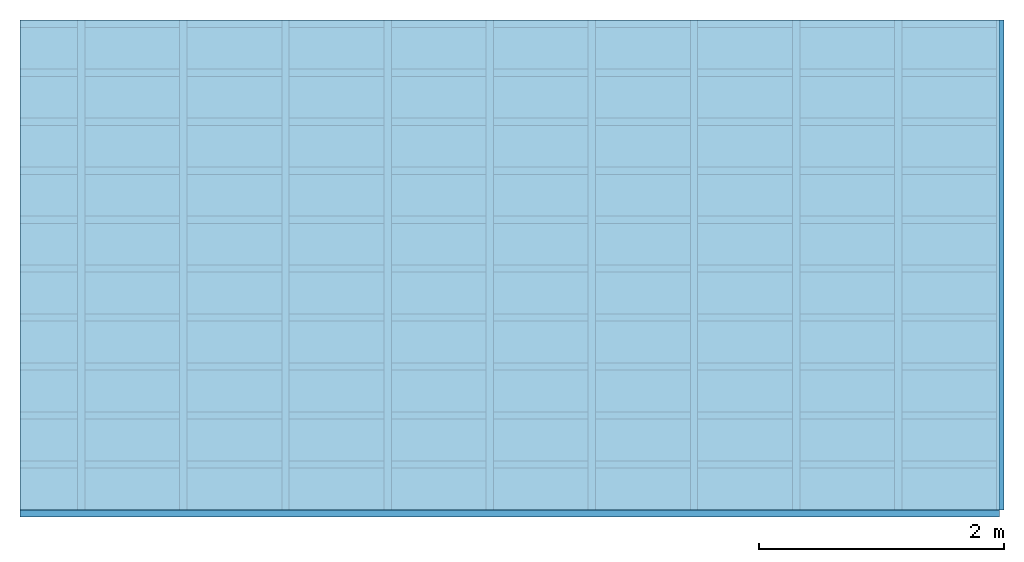
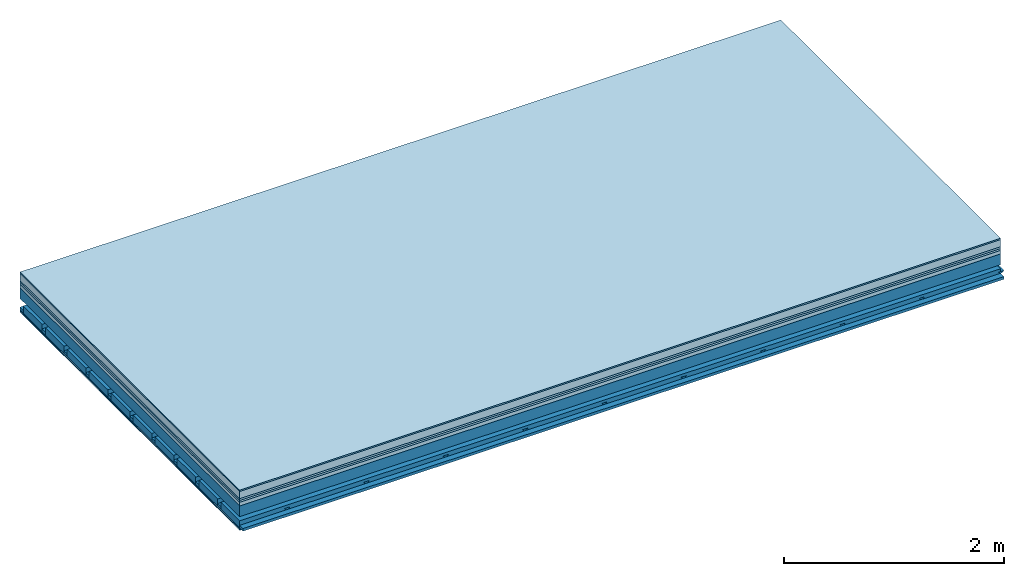
# One storey: 8 plates, 4 members, 1 element without a shape of its own.
"""IFC4 building model written with IfcOpenShell, lengths in metres."""

from ifc_helpers import new_model, si_unit, derived_unit, direction, frame, frame_2d, origin, origin_with_axes, place, context, project, spatial, polyline, rectangle, outline, extrude, material, layer, layer_set, type_object, element, aggregate, save


model = new_model("IFC4")

# Units and contexts
plan_context = context("Plan", 3, precision=1e-05, world=origin(), true_north=direction((0.0, 1.0)))
model_context = context("Model", 3, precision=1e-05, world=origin(), true_north=direction((0.0, 1.0)))
ifc_project = project(units=[si_unit("LENGTHUNIT", "METRE"), derived_unit("SOUNDPRESSUREUNIT", [(si_unit("PRESSUREUNIT", "PASCAL", prefix="MICRO"), 0)]), si_unit("ENERGYUNIT", "JOULE", prefix="MEGA"), si_unit("MASSUNIT", "GRAM", prefix="KILO"), derived_unit("THERMALTRANSMITTANCEUNIT", [(si_unit("POWERUNIT", "WATT"), 1), (si_unit("AREAUNIT", "SQUARE_METRE"), -1), (si_unit("THERMODYNAMICTEMPERATUREUNIT", "KELVIN"), -1)]), derived_unit("AREADENSITYUNIT", [(si_unit("MASSUNIT", "GRAM", prefix="KILO"), 1), (si_unit("AREAUNIT", "SQUARE_METRE"), -1)]), derived_unit("USERDEFINED", [(si_unit("ENERGYUNIT", "JOULE", prefix="MEGA"), 1), (si_unit("AREAUNIT", "SQUARE_METRE"), -1)])], contexts=[plan_context, model_context])

# Site, building, storey
site = spatial("IfcSite", under=ifc_project)
building_placement = place(None, origin())
building = spatial("IfcBuilding", under=site, at=building_placement)
storey_placement = place(building_placement, origin())
storey = spatial("IfcBuildingStorey", under=building, at=storey_placement)

# Slab, members, plates
ifc_material_1 = material(Category="11.013")
ifc_layer_1 = layer(ifc_material_1, 0.015, Name="Flooring")
ifc_material_2 = material(Name="Cement screed", Category="04.006")
ifc_layer_2 = layer(ifc_material_2, 0.08, Name="On-material")
ifc_material_3 = material(Name="Wood fiber generic product", Category="10.009")
ifc_layer_3 = layer(ifc_material_3, 0.02, Name="Impact sound insulation")
ifc_material_4 = material(Category="10.004")
ifc_layer_4 = layer(ifc_material_4, 0.02, Name="Additional insulation")
ifc_material_5 = material(Name="Garden plates", Category="02.007")
ifc_layer_5 = layer(ifc_material_5, 0.04, Name="on Supporting structure")
ifc_material_6 = material(Name="no composite action")
ifc_layer_6 = layer(ifc_material_6, 0.0, Name="Bond")
ifc_layer_7 = layer(None, 0.12, Name="Supporting structure")
ifc_layer_8 = layer(ifc_material_6, 0.0, Name="Bond")
ifc_layer_9 = layer(None, 0.095, Name="Coupling")
ifc_layer_10 = layer(None, 0.03, Name="Battens / profiles")
ifc_material_7 = material(Name="Plasterboard type A", Category="03.008")
ifc_layer_11 = layer(ifc_material_7, 0.0125, Name="Ceiling covering 1st layer")
ifc_layer_12 = layer(ifc_material_7, 0.0125, Name="Ceiling covering layer 2")
ifc_material_8 = material(Category="04.001")
ifc_layer_13 = layer(ifc_material_8, 0.003, Name="Surface / treatment")
ifc_layer_set = layer_set([ifc_layer_1, ifc_layer_2, ifc_layer_3, ifc_layer_4, ifc_layer_5, ifc_layer_6, ifc_layer_7, ifc_layer_8, ifc_layer_9, ifc_layer_10, ifc_layer_11, ifc_layer_12, ifc_layer_13])
slab_type = type_object("IfcSlabType", Name="A2168", PredefinedType="NOTDEFINED", material=ifc_layer_set)
slab_placement = place(None, frame((0.0, 0.0, 0.0), z_axis=(0.0, 0.0, -1.0), x_axis=(1.0, 0.0, 0.0)))
slab = element("IfcSlab", 1, at=slab_placement, inside=storey, type_object=slab_type, material=ifc_layer_set, Name="Slab #1")
ifc_material_9 = material(Name="Solid timber panel")
member_1_placement = place(slab_placement, origin())
member_1 = element("IfcMember", 2, at=member_1_placement, material=ifc_material_9, Name="Supporting structure", context=plan_context, shape_type="SweptSolid", body=[
    extrude(rectangle(XDim=1.0, YDim=0.12, at=frame_2d((0.5, 0.06), x_axis=(1.0, 0.0))), frame((0.0, 4.0, 0.175), z_axis=(0.0, -1.0, 0.0), x_axis=(1.0, 0.0, 0.0)), (0.0, 0.0, 1.0), 4.0),
    extrude(rectangle(XDim=1.0, YDim=0.12, at=frame_2d((0.5, 0.06), x_axis=(1.0, 0.0))), frame((1.0, 4.0, 0.175), z_axis=(0.0, -1.0, 0.0), x_axis=(1.0, 0.0, 0.0)), (0.0, 0.0, 1.0), 4.0),
    extrude(rectangle(XDim=1.0, YDim=0.12, at=frame_2d((0.5, 0.06), x_axis=(1.0, 0.0))), frame((2.0, 4.0, 0.175), z_axis=(0.0, -1.0, 0.0), x_axis=(1.0, 0.0, 0.0)), (0.0, 0.0, 1.0), 4.0),
    extrude(rectangle(XDim=1.0, YDim=0.12, at=frame_2d((0.5, 0.06), x_axis=(1.0, 0.0))), frame((3.0, 4.0, 0.175), z_axis=(0.0, -1.0, 0.0), x_axis=(1.0, 0.0, 0.0)), (0.0, 0.0, 1.0), 4.0),
    extrude(rectangle(XDim=1.0, YDim=0.12, at=frame_2d((0.5, 0.06), x_axis=(1.0, 0.0))), frame((4.0, 4.0, 0.175), z_axis=(0.0, -1.0, 0.0), x_axis=(1.0, 0.0, 0.0)), (0.0, 0.0, 1.0), 4.0),
    extrude(rectangle(XDim=1.0, YDim=0.12, at=frame_2d((0.5, 0.06), x_axis=(1.0, 0.0))), frame((5.0, 4.0, 0.175), z_axis=(0.0, -1.0, 0.0), x_axis=(1.0, 0.0, 0.0)), (0.0, 0.0, 1.0), 4.0),
    extrude(rectangle(XDim=1.0, YDim=0.12, at=frame_2d((0.5, 0.06), x_axis=(1.0, 0.0))), frame((6.0, 4.0, 0.175), z_axis=(0.0, -1.0, 0.0), x_axis=(1.0, 0.0, 0.0)), (0.0, 0.0, 1.0), 4.0),
    extrude(rectangle(XDim=1.0, YDim=0.12, at=frame_2d((0.5, 0.06), x_axis=(1.0, 0.0))), frame((7.0, 4.0, 0.175), z_axis=(0.0, -1.0, 0.0), x_axis=(1.0, 0.0, 0.0)), (0.0, 0.0, 1.0), 4.0),
])
ifc_material_10 = material()
member_2_placement = place(slab_placement, origin())
member_2 = element("IfcMember", 3, at=member_2_placement, material=ifc_material_10, Name="Coupling", context=plan_context, shape_type="SweptSolid", body=[
    extrude(outline(polyline([(0.0, 0.0), (0.06, 0.0), (0.04, 0.02), (0.02, 0.02), (0.0, 0.0)])), frame((0.47, 4.0, 0.37), z_axis=(0.0, -1.0, 0.0), x_axis=(1.0, 0.0, 0.0)), (0.0, 0.0, 1.0), 4.0),
    extrude(outline(polyline([(0.0, 0.0), (0.06, 0.0), (0.04, 0.02), (0.02, 0.02), (0.0, 0.0)])), frame((1.304, 4.0, 0.37), z_axis=(0.0, -1.0, 0.0), x_axis=(1.0, 0.0, 0.0)), (0.0, 0.0, 1.0), 4.0),
    extrude(outline(polyline([(0.0, 0.0), (0.06, 0.0), (0.04, 0.02), (0.02, 0.02), (0.0, 0.0)])), frame((2.138, 4.0, 0.37), z_axis=(0.0, -1.0, 0.0), x_axis=(1.0, 0.0, 0.0)), (0.0, 0.0, 1.0), 4.0),
    extrude(outline(polyline([(0.0, 0.0), (0.06, 0.0), (0.04, 0.02), (0.02, 0.02), (0.0, 0.0)])), frame((2.972, 4.0, 0.37), z_axis=(0.0, -1.0, 0.0), x_axis=(1.0, 0.0, 0.0)), (0.0, 0.0, 1.0), 4.0),
    extrude(outline(polyline([(0.0, 0.0), (0.06, 0.0), (0.04, 0.02), (0.02, 0.02), (0.0, 0.0)])), frame((3.806, 4.0, 0.37), z_axis=(0.0, -1.0, 0.0), x_axis=(1.0, 0.0, 0.0)), (0.0, 0.0, 1.0), 4.0),
    extrude(outline(polyline([(0.0, 0.0), (0.06, 0.0), (0.04, 0.02), (0.02, 0.02), (0.0, 0.0)])), frame((4.64, 4.0, 0.37), z_axis=(0.0, -1.0, 0.0), x_axis=(1.0, 0.0, 0.0)), (0.0, 0.0, 1.0), 4.0),
    extrude(outline(polyline([(0.0, 0.0), (0.06, 0.0), (0.04, 0.02), (0.02, 0.02), (0.0, 0.0)])), frame((5.474, 4.0, 0.37), z_axis=(0.0, -1.0, 0.0), x_axis=(1.0, 0.0, 0.0)), (0.0, 0.0, 1.0), 4.0),
    extrude(outline(polyline([(0.0, 0.0), (0.06, 0.0), (0.04, 0.02), (0.02, 0.02), (0.0, 0.0)])), frame((6.308, 4.0, 0.37), z_axis=(0.0, -1.0, 0.0), x_axis=(1.0, 0.0, 0.0)), (0.0, 0.0, 1.0), 4.0),
    extrude(outline(polyline([(0.0, 0.0), (0.06, 0.0), (0.04, 0.02), (0.02, 0.02), (0.0, 0.0)])), frame((7.142, 4.0, 0.37), z_axis=(0.0, -1.0, 0.0), x_axis=(1.0, 0.0, 0.0)), (0.0, 0.0, 1.0), 4.0),
    extrude(outline(polyline([(0.0, 0.0), (0.06, 0.0), (0.04, 0.02), (0.02, 0.02), (0.0, 0.0)])), frame((7.976, 4.0, 0.37), z_axis=(0.0, -1.0, 0.0), x_axis=(1.0, 0.0, 0.0)), (0.0, 0.0, 1.0), 4.0),
])
member_3_placement = place(slab_placement, origin())
member_3 = element("IfcMember", 4, at=member_3_placement, material=ifc_material_10, Name="Battens / profiles", context=plan_context, shape_type="SweptSolid", body=[
    extrude(rectangle(XDim=0.06, YDim=0.03, at=frame_2d((0.03, 0.015), x_axis=(1.0, 0.0))), frame((0.0, 0.0, 0.39), z_axis=(1.0, 0.0, 0.0), x_axis=(0.0, 1.0, 0.0)), (0.0, 0.0, 1.0), 8.0),
    extrude(rectangle(XDim=0.06, YDim=0.03, at=frame_2d((0.03, 0.015), x_axis=(1.0, 0.0))), frame((0.0, 0.4, 0.39), z_axis=(1.0, 0.0, 0.0), x_axis=(0.0, 1.0, 0.0)), (0.0, 0.0, 1.0), 8.0),
    extrude(rectangle(XDim=0.06, YDim=0.03, at=frame_2d((0.03, 0.015), x_axis=(1.0, 0.0))), frame((0.0, 0.8, 0.39), z_axis=(1.0, 0.0, 0.0), x_axis=(0.0, 1.0, 0.0)), (0.0, 0.0, 1.0), 8.0),
    extrude(rectangle(XDim=0.06, YDim=0.03, at=frame_2d((0.03, 0.015), x_axis=(1.0, 0.0))), frame((0.0, 1.2, 0.39), z_axis=(1.0, 0.0, 0.0), x_axis=(0.0, 1.0, 0.0)), (0.0, 0.0, 1.0), 8.0),
    extrude(rectangle(XDim=0.06, YDim=0.03, at=frame_2d((0.03, 0.015), x_axis=(1.0, 0.0))), frame((0.0, 1.6, 0.39), z_axis=(1.0, 0.0, 0.0), x_axis=(0.0, 1.0, 0.0)), (0.0, 0.0, 1.0), 8.0),
    extrude(rectangle(XDim=0.06, YDim=0.03, at=frame_2d((0.03, 0.015), x_axis=(1.0, 0.0))), frame((0.0, 2.0, 0.39), z_axis=(1.0, 0.0, 0.0), x_axis=(0.0, 1.0, 0.0)), (0.0, 0.0, 1.0), 8.0),
    extrude(rectangle(XDim=0.06, YDim=0.03, at=frame_2d((0.03, 0.015), x_axis=(1.0, 0.0))), frame((0.0, 2.4, 0.39), z_axis=(1.0, 0.0, 0.0), x_axis=(0.0, 1.0, 0.0)), (0.0, 0.0, 1.0), 8.0),
    extrude(rectangle(XDim=0.06, YDim=0.03, at=frame_2d((0.03, 0.015), x_axis=(1.0, 0.0))), frame((0.0, 2.8, 0.39), z_axis=(1.0, 0.0, 0.0), x_axis=(0.0, 1.0, 0.0)), (0.0, 0.0, 1.0), 8.0),
    extrude(rectangle(XDim=0.06, YDim=0.03, at=frame_2d((0.03, 0.015), x_axis=(1.0, 0.0))), frame((0.0, 3.2, 0.39), z_axis=(1.0, 0.0, 0.0), x_axis=(0.0, 1.0, 0.0)), (0.0, 0.0, 1.0), 8.0),
    extrude(rectangle(XDim=0.06, YDim=0.03, at=frame_2d((0.03, 0.015), x_axis=(1.0, 0.0))), frame((0.0, 3.6, 0.39), z_axis=(1.0, 0.0, 0.0), x_axis=(0.0, 1.0, 0.0)), (0.0, 0.0, 1.0), 8.0),
    extrude(rectangle(XDim=0.06, YDim=0.03, at=frame_2d((0.03, 0.015), x_axis=(1.0, 0.0))), frame((0.0, 4.0, 0.39), z_axis=(1.0, 0.0, 0.0), x_axis=(0.0, 1.0, 0.0)), (0.0, 0.0, 1.0), 8.0),
])
ifc_material_11 = material()
member_4_placement = place(slab_placement, origin())
member_4 = element("IfcMember", 5, at=member_4_placement, material=ifc_material_11, Name="Cavity", context=plan_context, shape_type="SweptSolid", body=[
    extrude(rectangle(XDim=0.34, YDim=0.08, at=frame_2d((0.17, 0.04), x_axis=(1.0, 0.0))), frame((0.0, 0.06, 0.34), z_axis=(1.0, 0.0, 0.0), x_axis=(0.0, 1.0, 0.0)), (0.0, 0.0, 1.0), 8.0),
    extrude(rectangle(XDim=0.34, YDim=0.08, at=frame_2d((0.17, 0.04), x_axis=(1.0, 0.0))), frame((0.0, 0.46, 0.34), z_axis=(1.0, 0.0, 0.0), x_axis=(0.0, 1.0, 0.0)), (0.0, 0.0, 1.0), 8.0),
    extrude(rectangle(XDim=0.34, YDim=0.08, at=frame_2d((0.17, 0.04), x_axis=(1.0, 0.0))), frame((0.0, 0.86, 0.34), z_axis=(1.0, 0.0, 0.0), x_axis=(0.0, 1.0, 0.0)), (0.0, 0.0, 1.0), 8.0),
    extrude(rectangle(XDim=0.34, YDim=0.08, at=frame_2d((0.17, 0.04), x_axis=(1.0, 0.0))), frame((0.0, 1.26, 0.34), z_axis=(1.0, 0.0, 0.0), x_axis=(0.0, 1.0, 0.0)), (0.0, 0.0, 1.0), 8.0),
    extrude(rectangle(XDim=0.34, YDim=0.08, at=frame_2d((0.17, 0.04), x_axis=(1.0, 0.0))), frame((0.0, 1.66, 0.34), z_axis=(1.0, 0.0, 0.0), x_axis=(0.0, 1.0, 0.0)), (0.0, 0.0, 1.0), 8.0),
    extrude(rectangle(XDim=0.34, YDim=0.08, at=frame_2d((0.17, 0.04), x_axis=(1.0, 0.0))), frame((0.0, 2.06, 0.34), z_axis=(1.0, 0.0, 0.0), x_axis=(0.0, 1.0, 0.0)), (0.0, 0.0, 1.0), 8.0),
    extrude(rectangle(XDim=0.34, YDim=0.08, at=frame_2d((0.17, 0.04), x_axis=(1.0, 0.0))), frame((0.0, 2.46, 0.34), z_axis=(1.0, 0.0, 0.0), x_axis=(0.0, 1.0, 0.0)), (0.0, 0.0, 1.0), 8.0),
    extrude(rectangle(XDim=0.34, YDim=0.08, at=frame_2d((0.17, 0.04), x_axis=(1.0, 0.0))), frame((0.0, 2.86, 0.34), z_axis=(1.0, 0.0, 0.0), x_axis=(0.0, 1.0, 0.0)), (0.0, 0.0, 1.0), 8.0),
    extrude(rectangle(XDim=0.34, YDim=0.08, at=frame_2d((0.17, 0.04), x_axis=(1.0, 0.0))), frame((0.0, 3.26, 0.34), z_axis=(1.0, 0.0, 0.0), x_axis=(0.0, 1.0, 0.0)), (0.0, 0.0, 1.0), 8.0),
    extrude(rectangle(XDim=0.34, YDim=0.08, at=frame_2d((0.17, 0.04), x_axis=(1.0, 0.0))), frame((0.0, 3.66, 0.34), z_axis=(1.0, 0.0, 0.0), x_axis=(0.0, 1.0, 0.0)), (0.0, 0.0, 1.0), 8.0),
])
plate_1_placement = place(slab_placement, origin())
plate_1 = element("IfcPlate", 6, at=plate_1_placement, material=ifc_material_1, Name="Flooring", context=plan_context, shape_type="SweptSolid", body=[
    extrude(rectangle(XDim=8.0, YDim=4.0, at=frame_2d((4.0, 2.0), x_axis=(1.0, 0.0))), origin_with_axes(), (0.0, 0.0, 1.0), 0.015),
])
plate_2_placement = place(slab_placement, origin())
plate_2 = element("IfcPlate", 7, at=plate_2_placement, material=ifc_material_2, Name="On-material", context=plan_context, shape_type="SweptSolid", body=[
    extrude(rectangle(XDim=8.0, YDim=4.0, at=frame_2d((4.0, 2.0), x_axis=(1.0, 0.0))), frame((0.0, 0.0, 0.015), z_axis=(0.0, 0.0, 1.0), x_axis=(1.0, 0.0, 0.0)), (0.0, 0.0, 1.0), 0.08),
])
plate_3_placement = place(slab_placement, origin())
plate_3 = element("IfcPlate", 8, at=plate_3_placement, material=ifc_material_3, Name="Impact sound insulation", context=plan_context, shape_type="SweptSolid", body=[
    extrude(rectangle(XDim=8.0, YDim=4.0, at=frame_2d((4.0, 2.0), x_axis=(1.0, 0.0))), frame((0.0, 0.0, 0.095), z_axis=(0.0, 0.0, 1.0), x_axis=(1.0, 0.0, 0.0)), (0.0, 0.0, 1.0), 0.02),
])
plate_4_placement = place(slab_placement, origin())
plate_4 = element("IfcPlate", 9, at=plate_4_placement, material=ifc_material_4, Name="Additional insulation", context=plan_context, shape_type="SweptSolid", body=[
    extrude(rectangle(XDim=8.0, YDim=4.0, at=frame_2d((4.0, 2.0), x_axis=(1.0, 0.0))), frame((0.0, 0.0, 0.115), z_axis=(0.0, 0.0, 1.0), x_axis=(1.0, 0.0, 0.0)), (0.0, 0.0, 1.0), 0.02),
])
plate_5_placement = place(slab_placement, origin())
plate_5 = element("IfcPlate", 10, at=plate_5_placement, material=ifc_material_5, Name="on Supporting structure", context=plan_context, shape_type="SweptSolid", body=[
    extrude(rectangle(XDim=8.0, YDim=4.0, at=frame_2d((4.0, 2.0), x_axis=(1.0, 0.0))), frame((0.0, 0.0, 0.135), z_axis=(0.0, 0.0, 1.0), x_axis=(1.0, 0.0, 0.0)), (0.0, 0.0, 1.0), 0.04),
])
plate_6_placement = place(slab_placement, origin())
plate_6 = element("IfcPlate", 11, at=plate_6_placement, material=ifc_material_7, Name="Ceiling covering 1st layer", context=plan_context, shape_type="SweptSolid", body=[
    extrude(rectangle(XDim=8.0, YDim=4.0, at=frame_2d((4.0, 2.0), x_axis=(1.0, 0.0))), frame((0.0, 0.0, 0.42), z_axis=(0.0, 0.0, 1.0), x_axis=(1.0, 0.0, 0.0)), (0.0, 0.0, 1.0), 0.0125),
])
plate_7_placement = place(slab_placement, origin())
plate_7 = element("IfcPlate", 12, at=plate_7_placement, material=ifc_material_7, Name="Ceiling covering layer 2", context=plan_context, shape_type="SweptSolid", body=[
    extrude(rectangle(XDim=8.0, YDim=4.0, at=frame_2d((4.0, 2.0), x_axis=(1.0, 0.0))), frame((0.0, 0.0, 0.4325), z_axis=(0.0, 0.0, 1.0), x_axis=(1.0, 0.0, 0.0)), (0.0, 0.0, 1.0), 0.0125),
])
plate_8_placement = place(slab_placement, origin())
plate_8 = element("IfcPlate", 13, at=plate_8_placement, material=ifc_material_8, Name="Surface / treatment", context=plan_context, shape_type="SweptSolid", body=[
    extrude(rectangle(XDim=8.0, YDim=4.0, at=frame_2d((4.0, 2.0), x_axis=(1.0, 0.0))), frame((0.0, 0.0, 0.445), z_axis=(0.0, 0.0, 1.0), x_axis=(1.0, 0.0, 0.0)), (0.0, 0.0, 1.0), 0.003),
])
aggregate(slab, [plate_1, plate_2, plate_3, plate_4, plate_5, member_1, member_2, member_3, member_4, plate_6, plate_7, plate_8])

save(model, "model.ifc")
